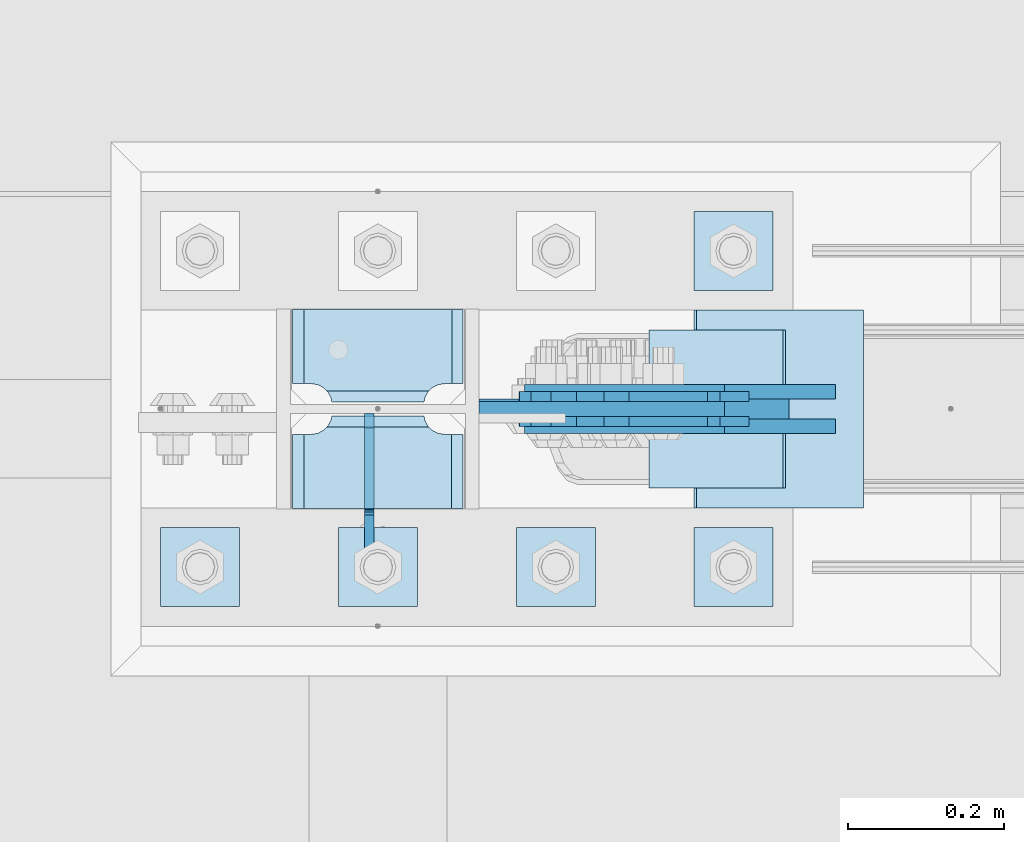
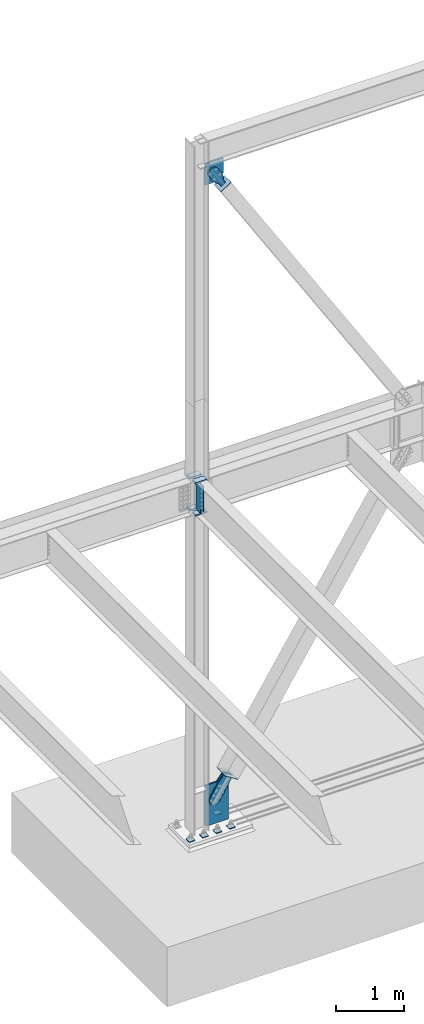
# One storey, part 3520 of 3843: 18 plates, 9 elements without a shape of their own.
"""IFC2X3 building model written with IfcOpenShell, lengths in millimetres."""

from ifc_helpers import new_model, si_unit, frame, origin_with_axes, place, context, subcontext, project, spatial, faceted_brep, material, type_object, element, aggregate, save


model = new_model("IFC2X3")

# Units and contexts
model_context = context("Model", 3, precision=1e-05, world=origin_with_axes())
body_context = subcontext(model_context, "Body", "Model", "MODEL_VIEW")
ifc_project = project(units=[si_unit("LENGTHUNIT", "METRE", prefix="MILLI"), si_unit("AREAUNIT", "SQUARE_METRE"), si_unit("VOLUMEUNIT", "CUBIC_METRE"), si_unit("MASSUNIT", "GRAM", prefix="KILO"), si_unit("TIMEUNIT", "SECOND"), si_unit("PLANEANGLEUNIT", "RADIAN"), si_unit("SOLIDANGLEUNIT", "STERADIAN"), si_unit("THERMODYNAMICTEMPERATUREUNIT", "DEGREE_CELSIUS"), si_unit("LUMINOUSINTENSITYUNIT", "LUMEN")], contexts=[model_context])

# Site, building, storey
site_placement = place(None, origin_with_axes())
site = spatial("IfcSite", under=ifc_project, at=site_placement, CompositionType="ELEMENT")
building_placement = place(site_placement, origin_with_axes())
building = spatial("IfcBuilding", under=site, at=building_placement, Name="Undefined", CompositionType="ELEMENT")
storey_placement = place(building_placement, origin_with_axes())
storey = spatial("IfcBuildingStorey", under=building, at=storey_placement, Name="Undefined", CompositionType="ELEMENT", Elevation=0.0)

# Assembly, plates
assembly_1_placement = place(storey_placement, origin_with_axes())
assembly_1 = element("IfcElementAssembly", 1, at=assembly_1_placement, inside=storey, Name="COLUMN", AssemblyPlace="NOTDEFINED", PredefinedType="RIGID_FRAME")
ifc_material_1 = material(Name="STEEL/A572-50")
plate_type_1 = type_object("IfcPlateType", PredefinedType="NOTDEFINED")
plate_1_placement = place(assembly_1_placement, frame((22972.7125, 104553.543750003, 35845.75), z_axis=(-1.0, 0.0, 0.0), x_axis=(0.0, -1.0, 0.0)))
plate_1 = element("IfcPlate", 2, at=plate_1_placement, type_object=plate_type_1, material=ifc_material_1, Name="PLATE", context=body_context, shape_type="Brep", body=[
    faceted_brep([(15.8628540477987, 9.2764413265686, 176.60415524448), (17.8394465694582, 12.6999999999971, 178.580747766144), (17.8394465694582, 12.6999999999971, 46.8442522338592), (15.8628540477985, 9.2764413265686, 48.8208447555226), (8.33959589993262, -3.75422402399272, 52.6541362449789), (3.17474995228986, -12.6999999999971, 53.4721674797547), (3.17474995228986, -12.6999999999971, 171.952832520248), (8.33959589993288, -3.75422402399272, 172.770863755024), (26.9874992430996, 12.6999999999971, 207.585803430506), (26.9874992435361, -12.6999999999971, 222.250500047681), (122.237500006479, -12.6999999999971, 222.250500047681), (122.237500006042, 12.6999999999971, 207.585803430506), (122.237500000527, 12.6999999999971, 17.8401965694902), (122.23750000009, -12.6999999999971, 3.17549995231457), (26.9874992371479, -12.6999999999971, 3.17549995231457), (26.9874992375844, 12.6999999999971, 17.8401965694902), (8.33959589993174, -12.6999999999971, 172.770863755024), (15.8628540477948, -12.6999999999971, 176.60415524448), (21.833345518462, -12.6999999999971, 182.574646715148), (21.833345518462, 12.6999999999971, 182.574646715148), (25.6666370079183, -12.6999999999971, 190.097904863011), (25.6666370079183, 12.6999999999971, 190.097904863011), (26.9874992370605, -12.6999999999971, 198.437500762942), (26.9874992370605, 12.6999999999971, 198.437500762942), (26.9874992370605, -12.6999999999971, 26.9874992370605), (26.9874992370605, 12.6999999999971, 26.9874992370605), (25.6666370079183, -12.6999999999971, 35.3270951369923), (25.6666370079183, 12.6999999999971, 35.3270951369923), (21.833345518462, -12.6999999999971, 42.8503532848626), (21.833345518462, 12.6999999999971, 42.8503532848626), (15.8628540477948, -12.6999999999971, 48.8208447555226), (8.33959589993174, -12.6999999999971, 52.6541362449789)], [[[0, 1, 2, 3, 4, 5, 6, 7]], [[8, 9, 10, 11]], [[12, 13, 14, 15]], [[16, 7, 6]], [[16, 17, 0, 7]], [[17, 18, 19, 1, 0]], [[18, 20, 21, 19]], [[20, 22, 23, 21]], [[23, 22, 9, 8]], [[13, 12, 11, 10]], [[24, 25, 15, 14]], [[24, 26, 27, 25]], [[26, 28, 29, 27]], [[29, 28, 30, 3, 2]], [[30, 31, 4, 3]], [[31, 5, 4]], [[19, 21, 23, 8, 11, 12, 15, 25, 27, 29, 2, 1]], [[31, 30, 28, 26, 24, 14, 13, 10, 9, 22, 20, 18, 17, 16, 6, 5]]]),
])
plate_2_placement = place(assembly_1_placement, frame((22972.7125, 104553.543750003, 36423.6), z_axis=(-1.0, 0.0, 0.0), x_axis=(0.0, -1.0, 0.0)))
plate_2 = element("IfcPlate", 3, at=plate_2_placement, type_object=plate_type_1, material=ifc_material_1, Name="PLATE", context=body_context, shape_type="Brep", body=[
    faceted_brep([(15.8628540477987, 9.2764413265686, 176.60415524448), (17.8394465694582, 12.6999999999971, 178.580747766144), (17.8394465694582, 12.6999999999971, 46.8442522338592), (15.8628540477985, 9.2764413265686, 48.8208447555226), (8.33959589993262, -3.75422402399272, 52.6541362449789), (3.17474995228986, -12.6999999999971, 53.4721674797547), (3.17474995228986, -12.6999999999971, 171.952832520248), (8.33959589993288, -3.75422402399272, 172.770863755024), (26.9874992430996, 12.6999999999971, 207.585803430506), (26.9874992435361, -12.6999999999971, 222.250500047681), (122.237500006479, -12.6999999999971, 222.250500047681), (122.237500006042, 12.6999999999971, 207.585803430506), (122.237500000527, 12.6999999999971, 17.8401965694902), (122.23750000009, -12.6999999999971, 3.17549995231457), (26.9874992371479, -12.6999999999971, 3.17549995231457), (26.9874992375844, 12.6999999999971, 17.8401965694902), (8.33959589993174, -12.6999999999971, 172.770863755024), (15.8628540477948, -12.6999999999971, 176.60415524448), (21.833345518462, -12.6999999999971, 182.574646715148), (21.833345518462, 12.6999999999971, 182.574646715148), (25.6666370079183, -12.6999999999971, 190.097904863011), (25.6666370079183, 12.6999999999971, 190.097904863011), (26.9874992370605, -12.6999999999971, 198.437500762942), (26.9874992370605, 12.6999999999971, 198.437500762942), (26.9874992370605, -12.6999999999971, 26.9874992370605), (26.9874992370605, 12.6999999999971, 26.9874992370605), (25.6666370079183, -12.6999999999971, 35.3270951369923), (25.6666370079183, 12.6999999999971, 35.3270951369923), (21.833345518462, -12.6999999999971, 42.8503532848626), (21.833345518462, 12.6999999999971, 42.8503532848626), (15.8628540477948, -12.6999999999971, 48.8208447555226), (8.33959589993174, -12.6999999999971, 52.6541362449789)], [[[0, 1, 2, 3, 4, 5, 6, 7]], [[8, 9, 10, 11]], [[12, 13, 14, 15]], [[16, 7, 6]], [[16, 17, 0, 7]], [[17, 18, 19, 1, 0]], [[18, 20, 21, 19]], [[20, 22, 23, 21]], [[23, 22, 9, 8]], [[13, 12, 11, 10]], [[24, 25, 15, 14]], [[24, 26, 27, 25]], [[26, 28, 29, 27]], [[29, 28, 30, 3, 2]], [[30, 31, 4, 3]], [[31, 5, 4]], [[19, 21, 23, 8, 11, 12, 15, 25, 27, 29, 2, 1]], [[31, 30, 28, 26, 24, 14, 13, 10, 9, 22, 20, 18, 17, 16, 6, 5]]]),
])
plate_3_placement = place(assembly_1_placement, frame((22972.7125, 104686.893750003, 35845.75), z_axis=(-1.0, 0.0, 0.0), x_axis=(0.0, -1.0, 0.0)))
plate_3 = element("IfcPlate", 4, at=plate_3_placement, type_object=plate_type_1, material=ifc_material_1, Name="PLATE", context=body_context, shape_type="Brep", body=[
    faceted_brep([(106.374645952202, 9.2764413265686, 48.8208447555226), (104.398053430486, 12.6999999999971, 46.8442522338009), (104.398053430486, 12.6999999999971, 178.580747766202), (106.374645952201, 9.2764413265686, 176.60415524448), (113.897904100067, -3.75422402399272, 172.770863755024), (119.062750047655, -12.6999999999971, 171.952832520255), (119.062750047655, -12.6999999999971, 53.4721674797474), (113.897904100067, -3.75422402399272, 52.6541362449789), (0.0, 12.6999999999971, 207.584803430516), (0.0, -12.6999999999971, 222.249500047692), (95.2500007629424, -12.6999999999971, 222.249500047692), (95.2500007629424, 12.6999999999971, 207.584803430516), (95.2500007629424, 12.6999999999971, 17.8391965694973), (95.2500007629424, -12.6999999999971, 3.17449995232164), (0.0, -12.6999999999971, 3.17449995232164), (0.0, 12.6999999999971, 17.8391965694973), (95.2500007629424, -12.6999999999971, 198.437500762942), (95.2500007629424, 12.6999999999971, 198.437500762942), (96.5708629920846, -12.6999999999971, 190.097904863011), (96.5708629920846, 12.6999999999971, 190.097904863011), (100.404154481541, -12.6999999999971, 182.574646715148), (100.404154481541, 12.6999999999971, 182.574646715148), (106.374645952208, -12.6999999999971, 176.60415524448), (113.897904100071, -12.6999999999971, 172.770863755024), (113.897904100071, -12.6999999999971, 52.6541362449789), (106.374645952208, -12.6999999999971, 48.8208447555226), (100.404154481541, -12.6999999999971, 42.8503532848626), (100.404154481541, 12.6999999999971, 42.8503532848626), (96.5708629920846, -12.6999999999971, 35.3270951369923), (96.5708629920846, 12.6999999999971, 35.3270951369923), (95.2500007629424, -12.6999999999971, 26.9874992370605), (95.2500007629424, 12.6999999999971, 26.9874992370605)], [[[0, 1, 2, 3, 4, 5, 6, 7]], [[8, 9, 10, 11]], [[12, 13, 14, 15]], [[15, 14, 9, 8]], [[16, 17, 11, 10]], [[16, 18, 19, 17]], [[18, 20, 21, 19]], [[21, 20, 22, 3, 2]], [[22, 23, 4, 3]], [[23, 5, 4]], [[24, 7, 6]], [[24, 25, 0, 7]], [[25, 26, 27, 1, 0]], [[26, 28, 29, 27]], [[28, 30, 31, 29]], [[31, 30, 13, 12]], [[27, 29, 31, 12, 15, 8, 11, 17, 19, 21, 2, 1]], [[13, 30, 28, 26, 25, 24, 6, 5, 23, 22, 20, 18, 16, 10, 9, 14]]]),
])
plate_4_placement = place(assembly_1_placement, frame((22972.7125, 104686.893750003, 36423.6), z_axis=(-1.0, 0.0, 0.0), x_axis=(0.0, -1.0, 0.0)))
plate_4 = element("IfcPlate", 5, at=plate_4_placement, type_object=plate_type_1, material=ifc_material_1, Name="PLATE", context=body_context, shape_type="Brep", body=[
    faceted_brep([(106.374645952202, 9.2764413265686, 48.8208447555226), (104.398053430486, 12.6999999999971, 46.8442522338009), (104.398053430486, 12.6999999999971, 178.580747766202), (106.374645952201, 9.2764413265686, 176.60415524448), (113.897904100067, -3.75422402399272, 172.770863755024), (119.062750047655, -12.6999999999971, 171.952832520255), (119.062750047655, -12.6999999999971, 53.4721674797474), (113.897904100067, -3.75422402399272, 52.6541362449789), (0.0, 12.6999999999971, 207.584803430516), (0.0, -12.6999999999971, 222.249500047692), (95.2500007629424, -12.6999999999971, 222.249500047692), (95.2500007629424, 12.6999999999971, 207.584803430516), (95.2500007629424, 12.6999999999971, 17.8391965694973), (95.2500007629424, -12.6999999999971, 3.17449995232164), (0.0, -12.6999999999971, 3.17449995232164), (0.0, 12.6999999999971, 17.8391965694973), (95.2500007629424, -12.6999999999971, 198.437500762942), (95.2500007629424, 12.6999999999971, 198.437500762942), (96.5708629920846, -12.6999999999971, 190.097904863011), (96.5708629920846, 12.6999999999971, 190.097904863011), (100.404154481541, -12.6999999999971, 182.574646715148), (100.404154481541, 12.6999999999971, 182.574646715148), (106.374645952208, -12.6999999999971, 176.60415524448), (113.897904100071, -12.6999999999971, 172.770863755024), (113.897904100071, -12.6999999999971, 52.6541362449789), (106.374645952208, -12.6999999999971, 48.8208447555226), (100.404154481541, -12.6999999999971, 42.8503532848626), (100.404154481541, 12.6999999999971, 42.8503532848626), (96.5708629920846, -12.6999999999971, 35.3270951369923), (96.5708629920846, 12.6999999999971, 35.3270951369923), (95.2500007629424, -12.6999999999971, 26.9874992370605), (95.2500007629424, 12.6999999999971, 26.9874992370605)], [[[0, 1, 2, 3, 4, 5, 6, 7]], [[8, 9, 10, 11]], [[12, 13, 14, 15]], [[15, 14, 9, 8]], [[16, 17, 11, 10]], [[16, 18, 19, 17]], [[18, 20, 21, 19]], [[21, 20, 22, 3, 2]], [[22, 23, 4, 3]], [[23, 5, 4]], [[24, 7, 6]], [[24, 25, 0, 7]], [[25, 26, 27, 1, 0]], [[26, 28, 29, 27]], [[28, 30, 31, 29]], [[31, 30, 13, 12]], [[27, 29, 31, 12, 15, 8, 11, 17, 19, 21, 2, 1]], [[13, 30, 28, 26, 25, 24, 6, 5, 23, 22, 20, 18, 16, 10, 9, 14]]]),
])

# Assembly, plate
assembly_2_placement = place(storey_placement, origin_with_axes())
assembly_2 = element("IfcElementAssembly", 6, at=assembly_2_placement, inside=storey, Name="CB", AssemblyPlace="NOTDEFINED", PredefinedType="RIGID_FRAME")
plate_type_2 = type_object("IfcPlateType", PredefinedType="NOTDEFINED")
plate_5_placement = place(assembly_2_placement, frame((23305.4642448749, 104559.1, 42002.075), z_axis=(0.0, 0.0, -1.0), x_axis=(-1.0, 0.0, 0.0)))
plate_5 = element("IfcPlate", 7, at=plate_5_placement, type_object=plate_type_2, material=ifc_material_1, Name="CB", context=body_context, shape_type="Brep", body=[
    faceted_brep([(0.0, -9.52500000000146, 0.0), (0.0, -9.52500000174041, 261.15819008874), (0.0, 9.52499999824795, 261.15819008874), (0.0, 9.52500000000146, 0.0), (196.587902692983, -9.52500000254076, 383.929714229205), (196.587902692983, 9.52499999746215, 383.929714229205), (315.289254935127, -9.52500000254076, 383.929714229205), (315.289254935127, 9.52499999746215, 383.929714229205), (315.289254935127, -9.52500000002328, -7.27595761418343e-12), (315.289254935127, 9.52499999996508, -7.27595761418343e-12)], [[[0, 1, 2, 3]], [[1, 4, 5, 2]], [[4, 6, 7, 5]], [[6, 8, 9, 7]], [[8, 0, 3, 9]], [[5, 7, 9, 3, 2]], [[8, 6, 4, 1, 0]]]),
])
aggregate(assembly_2, [plate_5])

assembly_3_placement = place(storey_placement, origin_with_axes())
assembly_3 = element("IfcElementAssembly", 8, at=assembly_3_placement, inside=storey, AssemblyPlace="NOTDEFINED", PredefinedType="RIGID_FRAME")
ifc_material_2 = material(Name="STEEL/A36")
plate_type_3 = type_object("IfcPlateType", PredefinedType="NOTDEFINED")
plate_6_placement = place(assembly_3_placement, frame((23299.8341977767, 104574.975, 41617.6154819446), z_axis=(-0.848184242014813, 0.0, -0.529701323009256), x_axis=(0.529701323009257, 0.0, -0.848184242014813)))
plate_6 = element("IfcPlate", 9, at=plate_6_placement, type_object=plate_type_3, material=ifc_material_2, context=body_context, shape_type="Brep", body=[
    faceted_brep([(0.0, -6.3499999046162, 0.0), (-101.599999999482, -6.35000000000582, -44.6881937832222), (-101.599999999482, 6.35000000000582, -44.6881937832222), (7.27595761418343e-12, 6.3499999046162, 0.0), (-246.684985846376, -6.35000000000582, -44.6881937832586), (-246.684985846376, 6.35000000000582, -44.6881937832586), (-281.313054100305, -6.35000000000582, -37.8002427490646), (-281.313054100305, 6.35000000000582, -37.8002427490646), (-310.669312866783, -6.35000000000582, -18.18501775197), (-310.669312866783, 6.35000000000582, -18.18501775197), (-330.284537863758, -6.35000000000582, 11.1712410146756), (-330.284537863758, 6.35000000000582, 11.1712410146756), (-337.172488897893, -6.35000000000582, 45.7993031645856), (-337.172488897893, 6.35000000000582, 45.7993031645856), (-330.284537863699, -6.35000000000582, 80.4273714186893), (-330.284537863699, 6.35000000000582, 80.4273714186893), (-310.669312866681, -6.35000000000582, 109.783630185331), (-310.669312866681, 6.35000000000582, 109.783630185331), (-281.313054100174, -6.35000000000582, 129.39885518244), (-281.313054100174, 6.35000000000582, 129.39885518244), (-246.684988898312, -6.35000000000582, 136.286806216667), (-246.684988898312, 6.35000000000582, 136.286806216667), (-101.599999999322, -6.35000000000582, 136.286806216689), (-101.599999999322, 6.35000000000582, 136.286806216689), (2.18278728425503e-10, -6.35000000000582, 91.5986124321353), (2.18278728425503e-10, 6.35000000000582, 91.5986124321353), (69.8499999987471, -6.35000000000582, 91.598612432037), (69.8499999987471, 6.35000000000582, 91.598612432037), (69.8499999985434, -6.35000000000582, -8.73114913702011e-11), (69.8499999985434, 6.35000000000582, -8.73114913702011e-11)], [[[0, 1, 2, 3]], [[1, 4, 5, 2]], [[4, 6, 7, 5]], [[6, 8, 9, 7]], [[8, 10, 11, 9]], [[10, 12, 13, 11]], [[12, 14, 15, 13]], [[14, 16, 17, 15]], [[16, 18, 19, 17]], [[18, 20, 21, 19]], [[20, 22, 23, 21]], [[22, 24, 25, 23]], [[24, 26, 27, 25]], [[26, 28, 29, 27]], [[28, 0, 3, 29]], [[5, 7, 9, 11, 13, 15, 17, 19, 21, 23, 25, 27, 29, 3, 2]], [[28, 26, 24, 22, 20, 18, 16, 14, 12, 10, 8, 6, 4, 1, 0]]]),
])
aggregate(assembly_3, [plate_6])

assembly_4_placement = place(storey_placement, origin_with_axes())
assembly_4 = element("IfcElementAssembly", 10, at=assembly_4_placement, inside=storey, AssemblyPlace="NOTDEFINED", PredefinedType="RIGID_FRAME")
plate_7_placement = place(assembly_4_placement, frame((23299.8341977767, 104543.225, 41617.6154819446), z_axis=(-0.848184242014813, 0.0, -0.529701323009256), x_axis=(0.529701323009257, 0.0, -0.848184242014813)))
plate_7 = element("IfcPlate", 11, at=plate_7_placement, type_object=plate_type_3, material=ifc_material_2, context=body_context, shape_type="Brep", body=[
    faceted_brep([(0.0, -6.3499999046162, 0.0), (-101.599999999482, -6.35000000000582, -44.6881937832222), (-101.599999999482, 6.35000000000582, -44.6881937832222), (7.27595761418343e-12, 6.3499999046162, 0.0), (-246.684985846376, -6.35000000000582, -44.6881937832586), (-246.684985846376, 6.35000000000582, -44.6881937832586), (-281.313054100305, -6.35000000000582, -37.8002427490646), (-281.313054100305, 6.35000000000582, -37.8002427490646), (-310.669312866783, -6.35000000000582, -18.18501775197), (-310.669312866783, 6.35000000000582, -18.18501775197), (-330.284537863758, -6.35000000000582, 11.1712410146756), (-330.284537863758, 6.35000000000582, 11.1712410146756), (-337.172488897893, -6.35000000000582, 45.7993031645856), (-337.172488897893, 6.35000000000582, 45.7993031645856), (-330.284537863699, -6.35000000000582, 80.4273714186893), (-330.284537863699, 6.35000000000582, 80.4273714186893), (-310.669312866681, -6.35000000000582, 109.783630185331), (-310.669312866681, 6.35000000000582, 109.783630185331), (-281.313054100174, -6.35000000000582, 129.39885518244), (-281.313054100174, 6.35000000000582, 129.39885518244), (-246.684988898312, -6.35000000000582, 136.286806216667), (-246.684988898312, 6.35000000000582, 136.286806216667), (-101.599999999322, -6.35000000000582, 136.286806216689), (-101.599999999322, 6.35000000000582, 136.286806216689), (2.18278728425503e-10, -6.35000000000582, 91.5986124321353), (2.18278728425503e-10, 6.35000000000582, 91.5986124321353), (69.8499999987471, -6.35000000000582, 91.598612432037), (69.8499999987471, 6.35000000000582, 91.598612432037), (69.8499999985434, -6.35000000000582, -8.73114913702011e-11), (69.8499999985434, 6.35000000000582, -8.73114913702011e-11)], [[[0, 1, 2, 3]], [[1, 4, 5, 2]], [[4, 6, 7, 5]], [[6, 8, 9, 7]], [[8, 10, 11, 9]], [[10, 12, 13, 11]], [[12, 14, 15, 13]], [[14, 16, 17, 15]], [[16, 18, 19, 17]], [[18, 20, 21, 19]], [[20, 22, 23, 21]], [[22, 24, 25, 23]], [[24, 26, 27, 25]], [[26, 28, 29, 27]], [[28, 0, 3, 29]], [[5, 7, 9, 11, 13, 15, 17, 19, 21, 23, 25, 27, 29, 3, 2]], [[28, 26, 24, 22, 20, 18, 16, 14, 12, 10, 8, 6, 4, 1, 0]]]),
])
aggregate(assembly_4, [plate_7])

assembly_5_placement = place(storey_placement, origin_with_axes())
assembly_5 = element("IfcElementAssembly", 12, at=assembly_5_placement, inside=storey, Name="Plate", AssemblyPlace="NOTDEFINED", PredefinedType="RIGID_FRAME")
plate_type_4 = type_object("IfcPlateType", PredefinedType="NOTDEFINED")
plate_8_placement = place(assembly_5_placement, frame((23210.1302646703, 104660.7, 41482.9851900965), z_axis=(0.848184242014813, 0.0, 0.529701323009256), x_axis=(0.0, -1.0, 0.0)))
plate_8 = element("IfcPlate", 13, at=plate_8_placement, type_object=plate_type_4, material=ifc_material_2, Name="Plate", context=body_context, shape_type="Brep", body=[
    faceted_brep([(0.0, -3.17499999999927, 0.0), (0.0, -3.17500000043947, 203.200000001736), (0.0, 3.1749999995518, 203.200000001743), (0.0, 3.17499999999927, 0.0), (203.200000000012, -3.17500000043947, 203.200000001736), (203.200000000012, 3.1749999995518, 203.200000001743), (203.199996948242, -3.17499999999927, 0.0), (203.199996948242, 3.17499999999927, 0.0)], [[[0, 1, 2, 3]], [[1, 4, 5, 2]], [[4, 6, 7, 5]], [[6, 0, 3, 7]], [[5, 7, 3, 2]], [[6, 4, 1, 0]]]),
])
aggregate(assembly_5, [plate_8])

# Assembly, plates
assembly_6_placement = place(storey_placement, origin_with_axes())
assembly_6 = element("IfcElementAssembly", 14, at=assembly_6_placement, inside=storey, Name="TEMPLATE", AssemblyPlace="NOTDEFINED", PredefinedType="RIGID_FRAME")
plate_type_5 = type_object("IfcPlateType", PredefinedType="NOTDEFINED")
plate_9_placement = place(assembly_6_placement, frame((23266.4, 104406.7, 30130.75), z_axis=(0.0, -1.0, 0.0), x_axis=(1.0, 0.0, 0.0)))
plate_9 = element("IfcPlate", 15, at=plate_9_placement, type_object=plate_type_5, material=ifc_material_1, Name="Washer Plate", context=body_context, shape_type="Brep", body=[
    faceted_brep([(0.0, -6.3499999046162, 0.0), (-1.67347025126219e-10, -6.35000000000582, 101.600000000151), (-1.67347025126219e-10, 6.35000000000582, 101.600000000151), (7.27595761418343e-12, 6.3499999046162, 0.0), (101.599998474121, -6.34999999999854, 101.599998474121), (101.599998474121, 6.34999999999854, 101.599998474121), (101.6, -6.34999999999854, 0.0), (101.6, 6.34999999999854, 0.0)], [[[0, 1, 2, 3]], [[1, 4, 5, 2]], [[4, 6, 7, 5]], [[6, 0, 3, 7]], [[5, 7, 3, 2]], [[6, 4, 1, 0]]]),
])
plate_10_placement = place(assembly_6_placement, frame((23266.4, 104813.1, 30130.75), z_axis=(0.0, -1.0, 0.0), x_axis=(1.0, 0.0, 0.0)))
plate_10 = element("IfcPlate", 16, at=plate_10_placement, type_object=plate_type_5, material=ifc_material_1, Name="Washer Plate", context=body_context, shape_type="Brep", body=[
    faceted_brep([(0.0, -6.3499999046162, 0.0), (-1.67347025126219e-10, -6.35000000000582, 101.600000000151), (-1.67347025126219e-10, 6.35000000000582, 101.600000000151), (7.27595761418343e-12, 6.3499999046162, 0.0), (101.599998474121, -6.34999999999854, 101.599998474121), (101.599998474121, 6.34999999999854, 101.599998474121), (101.6, -6.34999999999854, 0.0), (101.6, 6.34999999999854, 0.0)], [[[0, 1, 2, 3]], [[1, 4, 5, 2]], [[4, 6, 7, 5]], [[6, 0, 3, 7]], [[5, 7, 3, 2]], [[6, 4, 1, 0]]]),
])
plate_11_placement = place(assembly_6_placement, frame((23037.8, 104406.7, 30130.75), z_axis=(0.0, -1.0, 0.0), x_axis=(1.0, 0.0, 0.0)))
plate_11 = element("IfcPlate", 17, at=plate_11_placement, type_object=plate_type_5, material=ifc_material_1, Name="Washer Plate", context=body_context, shape_type="Brep", body=[
    faceted_brep([(0.0, -6.3499999046162, 0.0), (-1.67347025126219e-10, -6.35000000000582, 101.600000000151), (-1.67347025126219e-10, 6.35000000000582, 101.600000000151), (7.27595761418343e-12, 6.3499999046162, 0.0), (101.599998474121, -6.34999999999854, 101.599998474121), (101.599998474121, 6.34999999999854, 101.599998474121), (101.6, -6.34999999999854, 0.0), (101.6, 6.34999999999854, 0.0)], [[[0, 1, 2, 3]], [[1, 4, 5, 2]], [[4, 6, 7, 5]], [[6, 0, 3, 7]], [[5, 7, 3, 2]], [[6, 4, 1, 0]]]),
])
plate_12_placement = place(assembly_6_placement, frame((22809.2, 104406.7, 30130.75), z_axis=(0.0, -1.0, 0.0), x_axis=(1.0, 0.0, 0.0)))
plate_12 = element("IfcPlate", 18, at=plate_12_placement, type_object=plate_type_5, material=ifc_material_1, Name="Washer Plate", context=body_context, shape_type="Brep", body=[
    faceted_brep([(0.0, -6.3499999046162, 0.0), (-1.67347025126219e-10, -6.35000000000582, 101.600000000151), (-1.67347025126219e-10, 6.35000000000582, 101.600000000151), (7.27595761418343e-12, 6.3499999046162, 0.0), (101.599998474121, -6.34999999999854, 101.599998474121), (101.599998474121, 6.34999999999854, 101.599998474121), (101.6, -6.34999999999854, 0.0), (101.6, 6.34999999999854, 0.0)], [[[0, 1, 2, 3]], [[1, 4, 5, 2]], [[4, 6, 7, 5]], [[6, 0, 3, 7]], [[5, 7, 3, 2]], [[6, 4, 1, 0]]]),
])
plate_13_placement = place(assembly_6_placement, frame((22580.6, 104406.7, 30130.75), z_axis=(0.0, -1.0, 0.0), x_axis=(1.0, 0.0, 0.0)))
plate_13 = element("IfcPlate", 19, at=plate_13_placement, type_object=plate_type_5, material=ifc_material_1, Name="Washer Plate", context=body_context, shape_type="Brep", body=[
    faceted_brep([(0.0, -6.3499999046162, 0.0), (-1.67347025126219e-10, -6.35000000000582, 101.600000000151), (-1.67347025126219e-10, 6.35000000000582, 101.600000000151), (7.27595761418343e-12, 6.3499999046162, 0.0), (101.599998474121, -6.34999999999854, 101.599998474121), (101.599998474121, 6.34999999999854, 101.599998474121), (101.6, -6.34999999999854, 0.0), (101.6, 6.34999999999854, 0.0)], [[[0, 1, 2, 3]], [[1, 4, 5, 2]], [[4, 6, 7, 5]], [[6, 0, 3, 7]], [[5, 7, 3, 2]], [[6, 4, 1, 0]]]),
])
aggregate(assembly_6, [plate_9, plate_10, plate_11, plate_12, plate_13])

# Assembly, plate
assembly_7_placement = place(storey_placement, origin_with_axes())
assembly_7 = element("IfcElementAssembly", 20, at=assembly_7_placement, inside=storey, AssemblyPlace="NOTDEFINED", PredefinedType="RIGID_FRAME")
plate_type_6 = type_object("IfcPlateType", PredefinedType="NOTDEFINED")
plate_14_placement = place(assembly_7_placement, frame((23410.7506088412, 104581.325, 30835.3624223078), z_axis=(-0.844597156660866, 0.0, 0.535402318785024), x_axis=(0.535402318785024, 0.0, 0.844597156660866)))
plate_14 = element("IfcPlate", 21, at=plate_14_placement, type_object=plate_type_6, material=ifc_material_2, context=body_context, shape_type="Brep", body=[
    faceted_brep([(0.0, -9.52500000000146, 0.0), (-101.599999999351, -9.52499999999418, -12.3260213857429), (-101.599999999351, 9.52499999999418, -12.3260213857429), (0.0, 9.52500000000146, 0.0), (-364.729297663791, -9.52499999999418, -12.3260213864851), (-364.729297663791, 9.52499999999418, -12.3260213864851), (-401.787405129209, -9.52499999999418, -4.95470550008758), (-401.787405129209, 9.52499999999418, -4.95470550008758), (-433.203751665707, -9.52499999999418, 16.0370261367789), (-433.203751665707, 9.52499999999418, 16.0370261367789), (-454.195483303061, -9.52499999999418, 47.4533726729569), (-454.195483303061, 9.52499999999418, 47.4533726729569), (-461.566799190045, -9.52499999999418, 84.5114770857908), (-461.566799190045, 9.52499999999418, 84.5114770857908), (-454.195483303822, -9.52499999999418, 121.569584551733), (-454.195483303822, 9.52499999999418, 121.569584551733), (-433.203751666773, -9.52499999999418, 152.985931088682), (-433.203751666773, 9.52499999999418, 152.985931088682), (-401.787405130151, -9.52499999999418, 173.977662726218), (-401.787405130151, 9.52499999999418, 173.977662726218), (-364.729299191746, -9.52499999999418, 181.348978613009), (-364.729299191746, 9.52499999999418, 181.348978613009), (-101.600000001839, -9.52499999999418, 181.348978613736), (-101.600000001839, 9.52499999999418, 181.348978613736), (-2.16823536902666e-09, -9.52499999999418, 169.022957228546), (-2.16823536902666e-09, 9.52499999999418, 169.022957228546), (69.8499999974956, -9.52499999999418, 169.02295722875), (69.8499999974956, 9.52499999999418, 169.02295722875), (69.8499999979995, -9.52499999999418, -4.00177668780088e-10), (69.8499999979995, 9.52499999999418, -4.00177668780088e-10)], [[[0, 1, 2, 3]], [[1, 4, 5, 2]], [[4, 6, 7, 5]], [[6, 8, 9, 7]], [[8, 10, 11, 9]], [[10, 12, 13, 11]], [[12, 14, 15, 13]], [[14, 16, 17, 15]], [[16, 18, 19, 17]], [[18, 20, 21, 19]], [[20, 22, 23, 21]], [[22, 24, 25, 23]], [[24, 26, 27, 25]], [[26, 28, 29, 27]], [[28, 0, 3, 29]], [[5, 7, 9, 11, 13, 15, 17, 19, 21, 23, 25, 27, 29, 3, 2]], [[28, 26, 24, 22, 20, 18, 16, 14, 12, 10, 8, 6, 4, 1, 0]]]),
])
aggregate(assembly_7, [plate_14])

assembly_8_placement = place(storey_placement, origin_with_axes())
assembly_8 = element("IfcElementAssembly", 22, at=assembly_8_placement, inside=storey, AssemblyPlace="NOTDEFINED", PredefinedType="RIGID_FRAME")
plate_15_placement = place(assembly_8_placement, frame((23410.7506088412, 104536.875, 30835.3624223078), z_axis=(-0.844597156660866, 0.0, 0.535402318785024), x_axis=(0.535402318785024, 0.0, 0.844597156660866)))
plate_15 = element("IfcPlate", 23, at=plate_15_placement, type_object=plate_type_6, material=ifc_material_2, context=body_context, shape_type="Brep", body=[
    faceted_brep([(0.0, -9.52500000000146, 0.0), (-101.599999999351, -9.52499999999418, -12.3260213857429), (-101.599999999351, 9.52499999999418, -12.3260213857429), (0.0, 9.52500000000146, 0.0), (-364.729297663791, -9.52499999999418, -12.3260213864851), (-364.729297663791, 9.52499999999418, -12.3260213864851), (-401.787405129209, -9.52499999999418, -4.95470550008758), (-401.787405129209, 9.52499999999418, -4.95470550008758), (-433.203751665707, -9.52499999999418, 16.0370261367789), (-433.203751665707, 9.52499999999418, 16.0370261367789), (-454.195483303061, -9.52499999999418, 47.4533726729569), (-454.195483303061, 9.52499999999418, 47.4533726729569), (-461.566799190045, -9.52499999999418, 84.5114770857908), (-461.566799190045, 9.52499999999418, 84.5114770857908), (-454.195483303822, -9.52499999999418, 121.569584551733), (-454.195483303822, 9.52499999999418, 121.569584551733), (-433.203751666773, -9.52499999999418, 152.985931088682), (-433.203751666773, 9.52499999999418, 152.985931088682), (-401.787405130151, -9.52499999999418, 173.977662726218), (-401.787405130151, 9.52499999999418, 173.977662726218), (-364.729299191746, -9.52499999999418, 181.348978613009), (-364.729299191746, 9.52499999999418, 181.348978613009), (-101.600000001839, -9.52499999999418, 181.348978613736), (-101.600000001839, 9.52499999999418, 181.348978613736), (-2.16823536902666e-09, -9.52499999999418, 169.022957228546), (-2.16823536902666e-09, 9.52499999999418, 169.022957228546), (69.8499999974956, -9.52499999999418, 169.02295722875), (69.8499999974956, 9.52499999999418, 169.02295722875), (69.8499999979995, -9.52499999999418, -4.00177668780088e-10), (69.8499999979995, 9.52499999999418, -4.00177668780088e-10)], [[[0, 1, 2, 3]], [[1, 4, 5, 2]], [[4, 6, 7, 5]], [[6, 8, 9, 7]], [[8, 10, 11, 9]], [[10, 12, 13, 11]], [[12, 14, 15, 13]], [[14, 16, 17, 15]], [[16, 18, 19, 17]], [[18, 20, 21, 19]], [[20, 22, 23, 21]], [[22, 24, 25, 23]], [[24, 26, 27, 25]], [[26, 28, 29, 27]], [[28, 0, 3, 29]], [[5, 7, 9, 11, 13, 15, 17, 19, 21, 23, 25, 27, 29, 3, 2]], [[28, 26, 24, 22, 20, 18, 16, 14, 12, 10, 8, 6, 4, 1, 0]]]),
])
aggregate(assembly_8, [plate_15])

assembly_9_placement = place(storey_placement, origin_with_axes())
assembly_9 = element("IfcElementAssembly", 24, at=assembly_9_placement, inside=storey, Name="Plate", AssemblyPlace="NOTDEFINED", PredefinedType="RIGID_FRAME")
plate_type_7 = type_object("IfcPlateType", PredefinedType="NOTDEFINED")
plate_16_placement = place(assembly_9_placement, frame((23482.3342428735, 104432.1, 30868.927484783), z_axis=(-0.844597156660866, 0.0, 0.535402318785024), x_axis=(0.0, 1.0, 0.0)))
plate_16 = element("IfcPlate", 25, at=plate_16_placement, type_object=plate_type_7, material=ifc_material_2, Name="Plate", context=body_context, shape_type="Brep", body=[
    faceted_brep([(0.0, -3.17499999999927, 0.0), (0.0, -3.17499999965185, 254.000000005151), (0.0, 3.17500000035216, 254.000000005166), (0.0, 3.17499999999927, 0.0), (254.0, -3.17499999965185, 254.000000005151), (254.0, 3.17500000035216, 254.000000005166), (254.0, -3.17500000000291, 0.0), (254.0, 3.17499999999927, 1.45519152283669e-11)], [[[0, 1, 2, 3]], [[1, 4, 5, 2]], [[4, 6, 7, 5]], [[6, 0, 3, 7]], [[5, 7, 3, 2]], [[6, 4, 1, 0]]]),
])
aggregate(assembly_9, [plate_16])

# Plate
plate_type_8 = type_object("IfcPlateType", PredefinedType="NOTDEFINED")
plate_17_placement = place(assembly_1_placement, frame((22848.8874999046, 104553.54375, 35877.5), z_axis=(0.0, -0.707106781186682, 0.707106781186413), x_axis=(0.0, -0.707106781186548, -0.707106781186548)))
plate_17 = element("IfcPlate", 26, at=plate_17_placement, type_object=plate_type_8, material=ifc_material_1, Name="PLATE", context=body_context, shape_type="Brep", body=[
    faceted_brep([(0.0, -6.3499999046162, 0.0), (-363.700372901621, -6.34999999999854, 363.700372901469), (-363.700372901621, 6.34999999999854, 363.700372901469), (7.27595761418343e-12, 6.3499999046162, 0.0), (-363.700372901338, -6.34999999999854, 390.641141264845), (-363.700372901338, 6.34999999999854, 390.641141264845), (-290.174525774113, -6.34999999999854, 464.166988122408), (-290.174525774113, 6.34999999999854, 464.166988122408), (-286.054349305959, -6.34999999999854, 461.413974221941), (-286.054349305959, 6.34999999999854, 461.413974221941), (-281.194269787906, -6.34999999999854, 460.447244299372), (-281.194269787906, 6.34999999999854, 460.447244299372), (-276.334190269838, -6.34999999999854, 461.413974222), (-276.334190269838, 6.34999999999854, 461.413974222), (-272.214013801662, -6.34999999999854, 464.16698812251), (-272.214013801662, 6.34999999999854, 464.16698812251), (-218.332476939475, -6.34999999999854, 518.048524984726), (-218.332476939475, 6.34999999999854, 518.048524984726), (104.956743417526, -6.34999999999854, 194.759304627849), (104.956743417526, 6.34999999999854, 194.759304627849), (51.0752065553315, -6.34999999999854, 140.877767765633), (51.0752065553315, 6.34999999999854, 140.877767765633), (48.3221926548213, -6.34999999999854, 136.757591297457), (48.3221926548213, 6.34999999999854, 136.757591297457), (47.3554627322083, -6.34999999999854, 131.897511779389), (47.3554627322083, 6.34999999999854, 131.897511779389), (48.3221926547776, -6.34999999999854, 127.037432261335), (48.3221926547776, 6.34999999999854, 127.037432261335), (51.0752065552297, -6.34999999999854, 122.917255793189), (51.0752065552297, 6.34999999999854, 122.917255793189), (100.466615355741, -6.34999999999854, 73.5258469927066), (100.466615355741, 6.34999999999854, 73.5258469927066), (26.9407683632217, -6.34999999999854, 1.30967237055302e-10), (26.9407683632217, 6.34999999999854, 1.30967237055302e-10)], [[[0, 1, 2, 3]], [[1, 4, 5, 2]], [[4, 6, 7, 5]], [[6, 8, 9, 7]], [[8, 10, 11, 9]], [[10, 12, 13, 11]], [[12, 14, 15, 13]], [[14, 16, 17, 15]], [[16, 18, 19, 17]], [[18, 20, 21, 19]], [[20, 22, 23, 21]], [[22, 24, 25, 23]], [[24, 26, 27, 25]], [[26, 28, 29, 27]], [[28, 30, 31, 29]], [[30, 32, 33, 31]], [[32, 0, 3, 33]], [[5, 7, 9, 11, 13, 15, 17, 19, 21, 23, 25, 27, 29, 31, 33, 3, 2]], [[32, 30, 28, 26, 24, 22, 20, 18, 16, 14, 12, 10, 8, 6, 4, 1, 0]]]),
])

plate_type_9 = type_object("IfcPlateType", PredefinedType="NOTDEFINED")
plate_18_placement = place(assembly_1_placement, frame((22990.175, 104559.1, 30124.4), z_axis=(0.0, 0.0, 1.0), x_axis=(1.0, 0.0, 0.0)))
plate_18 = element("IfcPlate", 27, at=plate_18_placement, type_object=plate_type_9, material=ifc_material_1, Name="CB", context=body_context, shape_type="Brep", body=[
    faceted_brep([(0.0, -12.6999999999971, 19.0499992370605), (0.0, -12.6999999999971, 735.84523386979), (0.0, 12.6999999999971, 735.84523386979), (0.0, 12.6999999999971, 19.0499992370605), (191.55913378522, -12.6999999999971, 735.84523386979), (191.55913378522, 12.6999999999971, 735.84523386979), (398.042023589805, -12.6999999999971, 604.952751874273), (398.042023589805, 12.6999999999971, 604.952751874273), (398.042023589805, -12.6999999999971, 0.0), (398.042023589805, 12.6999999999971, 0.0), (19.0500015258731, -12.6999999999971, -6.33008312433958e-10), (19.0500015258731, 12.6999999999971, 0.0)], [[[0, 1, 2, 3]], [[1, 4, 5, 2]], [[4, 6, 7, 5]], [[6, 8, 9, 7]], [[8, 10, 11, 9]], [[10, 0, 3, 11]], [[5, 7, 9, 11, 3, 2]], [[10, 8, 6, 4, 1, 0]]]),
])

aggregate(assembly_1, [plate_18, plate_1, plate_2, plate_3, plate_4, plate_17])

save(model, "model.ifc")
